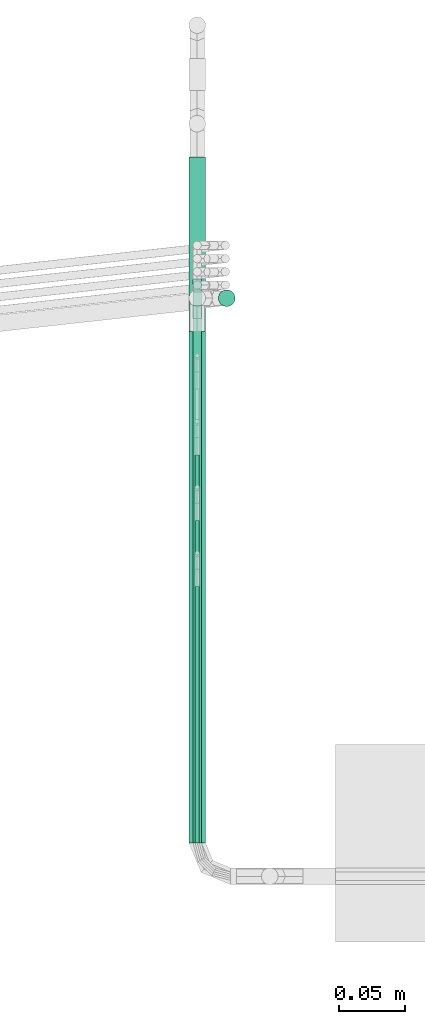
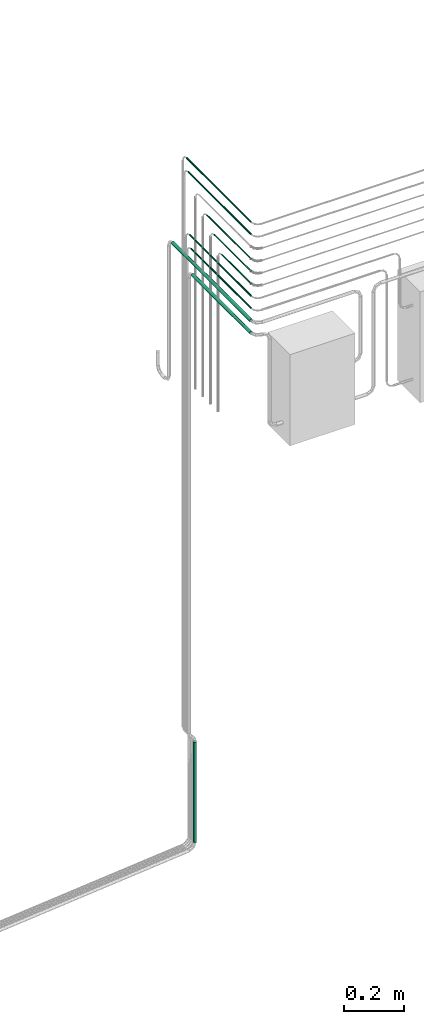
# One storey, part 20 of 45: 10 flow segments.
"""IFC2X3 building model written with IfcOpenShell, lengths in millimetres."""

from ifc_helpers import new_model, entity, si_unit, converted_unit, derived_unit, direction, frame, origin, origin_2d_with_axis, place, context, subcontext, project, spatial, circle, extrude, type_object, element, save


model = new_model("IFC2X3")

# Units and contexts
model_context = context("Model", 3, precision=0.01, world=origin(), true_north=direction((6.12303176911189e-17, 1.0)))
body_context = subcontext(model_context, "Body", "Model", "MODEL_VIEW")
ifc_project = project(units=[si_unit("LENGTHUNIT", "METRE", prefix="MILLI"), si_unit("AREAUNIT", "SQUARE_METRE"), si_unit("VOLUMEUNIT", "CUBIC_METRE"), converted_unit("PLANEANGLEUNIT", "DEGREE", entity("IfcRatioMeasure", 0.0174532925199433), si_unit("PLANEANGLEUNIT", "RADIAN"), dimensions=[0, 0, 0, 0, 0, 0, 0]), si_unit("MASSUNIT", "GRAM", prefix="KILO"), derived_unit("MASSDENSITYUNIT", [(si_unit("MASSUNIT", "GRAM", prefix="KILO"), 1), (si_unit("LENGTHUNIT", "METRE"), -3)]), derived_unit("MOMENTOFINERTIAUNIT", [(si_unit("LENGTHUNIT", "METRE"), 4)]), si_unit("TIMEUNIT", "SECOND"), si_unit("FREQUENCYUNIT", "HERTZ"), si_unit("THERMODYNAMICTEMPERATUREUNIT", "DEGREE_CELSIUS"), derived_unit("THERMALTRANSMITTANCEUNIT", [(si_unit("MASSUNIT", "GRAM", prefix="KILO"), 1), (si_unit("THERMODYNAMICTEMPERATUREUNIT", "KELVIN"), -1), (si_unit("TIMEUNIT", "SECOND"), -3)]), derived_unit("VOLUMETRICFLOWRATEUNIT", [(si_unit("LENGTHUNIT", "METRE"), 3), (si_unit("TIMEUNIT", "SECOND"), -1)]), derived_unit("MASSFLOWRATEUNIT", [(si_unit("MASSUNIT", "GRAM", prefix="KILO"), 1), (si_unit("TIMEUNIT", "SECOND"), -1)]), derived_unit("ROTATIONALFREQUENCYUNIT", [(si_unit("TIMEUNIT", "SECOND"), -1)]), si_unit("ELECTRICCURRENTUNIT", "AMPERE"), si_unit("ELECTRICVOLTAGEUNIT", "VOLT"), si_unit("POWERUNIT", "WATT"), si_unit("FORCEUNIT", "NEWTON", prefix="KILO"), si_unit("ILLUMINANCEUNIT", "LUX"), si_unit("LUMINOUSFLUXUNIT", "LUMEN"), si_unit("LUMINOUSINTENSITYUNIT", "CANDELA"), derived_unit("USERDEFINED", [(si_unit("MASSUNIT", "GRAM", prefix="KILO"), -1), (si_unit("LENGTHUNIT", "METRE"), -2), (si_unit("TIMEUNIT", "SECOND"), 3), (si_unit("LUMINOUSFLUXUNIT", "LUMEN"), 1)]), derived_unit("LINEARVELOCITYUNIT", [(si_unit("LENGTHUNIT", "METRE"), 1), (si_unit("TIMEUNIT", "SECOND"), -1)]), si_unit("PRESSUREUNIT", "PASCAL"), derived_unit("USERDEFINED", [(si_unit("LENGTHUNIT", "METRE"), -2), (si_unit("MASSUNIT", "GRAM", prefix="KILO"), 1), (si_unit("TIMEUNIT", "SECOND"), -2)]), derived_unit("LINEARFORCEUNIT", [(si_unit("MASSUNIT", "GRAM", prefix="KILO"), 1), (si_unit("LENGTHUNIT", "METRE"), 1), (si_unit("TIMEUNIT", "SECOND"), -2), (si_unit("LENGTHUNIT", "METRE"), -1)]), derived_unit("PLANARFORCEUNIT", [(si_unit("MASSUNIT", "GRAM", prefix="KILO"), 1), (si_unit("LENGTHUNIT", "METRE"), 1), (si_unit("TIMEUNIT", "SECOND"), -2), (si_unit("LENGTHUNIT", "METRE"), -2)])], contexts=[model_context])

# Site, building, storey
site_placement = place(None, frame((-24836.06, 8968.75, 0.0)))
site = spatial("IfcSite", under=ifc_project, at=site_placement, CompositionType="ELEMENT")
building_placement = place(site_placement, origin())
building = spatial("IfcBuilding", under=site, at=building_placement, CompositionType="ELEMENT")
storey_placement = place(building_placement, frame((0.0, 0.0, -4200.0)))
storey = spatial("IfcBuildingStorey", under=building, at=storey_placement, CompositionType="ELEMENT", Elevation=-4200.0)

# Flow segments
pipe_segment_type = type_object("IfcPipeSegmentType", PredefinedType="NOTDEFINED")
flow_segment_1_placement = place(storey_placement, frame((80740.98, -7563.35, 2045.23)))
element("IfcFlowSegment", 1, at=flow_segment_1_placement, inside=storey, type_object=pipe_segment_type, context=body_context, shape_type="SweptSolid", body=[
    extrude(circle(Radius=3.175, at=origin_2d_with_axis()), frame((4.77, 0.0, 4.77), z_axis=(0.0, 1.0, 0.0), x_axis=(-1.0, 0.0, 0.0)), (0.0, 0.0, 1.0), 398.712004781445),
])
flow_segment_2_placement = place(storey_placement, frame((80740.98, -7563.35, 2095.23)))
element("IfcFlowSegment", 2, at=flow_segment_2_placement, inside=storey, type_object=pipe_segment_type, context=body_context, shape_type="SweptSolid", body=[
    extrude(circle(Radius=3.175, at=origin_2d_with_axis()), frame((4.77, 0.0, 4.77), z_axis=(0.0, 1.0, 0.0), x_axis=(-1.0, 0.0, 0.0)), (0.0, 0.0, 1.0), 408.772453104694),
])
flow_segment_3_placement = place(storey_placement, frame((80740.98, -7563.35, 2345.23)))
element("IfcFlowSegment", 3, at=flow_segment_3_placement, inside=storey, type_object=pipe_segment_type, context=body_context, shape_type="SweptSolid", body=[
    extrude(circle(Radius=3.175, at=origin_2d_with_axis()), frame((4.77, 0.0, 4.77), z_axis=(0.0, 1.0, 0.0), x_axis=(-1.0, 0.0, 0.0)), (0.0, 0.0, 1.0), 418.83290142795),
])
flow_segment_4_placement = place(storey_placement, frame((80740.98, -7563.35, 2395.23)))
element("IfcFlowSegment", 4, at=flow_segment_4_placement, inside=storey, type_object=pipe_segment_type, context=body_context, shape_type="SweptSolid", body=[
    extrude(circle(Radius=3.175, at=origin_2d_with_axis()), frame((4.77, 0.0, 4.77), z_axis=(0.0, 1.0, 0.0), x_axis=(-1.0, 0.0, 0.0)), (0.0, 0.0, 1.0), 428.893349751199),
])
flow_segment_5_placement = place(storey_placement, frame((80760.28, -7157.13, -374.6)))
element("IfcFlowSegment", 5, at=flow_segment_5_placement, inside=storey, type_object=pipe_segment_type, context=body_context, shape_type="SweptSolid", body=[
    extrude(circle(Radius=6.35, at=origin_2d_with_axis()), frame((7.95, 7.95, 0.0), z_axis=(0.0, 0.0, 1.0), x_axis=(-1.0, 0.0, 0.0)), (0.0, 0.0, 1.0), 407.984401555602),
])
flow_segment_6_placement = place(storey_placement, frame((80737.81, -7563.35, 1942.05)))
element("IfcFlowSegment", 6, at=flow_segment_6_placement, inside=storey, type_object=pipe_segment_type, context=body_context, shape_type="SweptSolid", body=[
    extrude(circle(Radius=6.35, at=origin_2d_with_axis()), frame((7.95, 0.0, 7.95), z_axis=(0.0, 1.0, 0.0), x_axis=(-1.0, 0.0, 0.0)), (0.0, 0.0, 1.0), 388.772089900225),
])
flow_segment_7_placement = place(storey_placement, frame((80737.81, -7563.35, 1992.05)))
element("IfcFlowSegment", 7, at=flow_segment_7_placement, inside=storey, type_object=pipe_segment_type, context=body_context, shape_type="SweptSolid", body=[
    extrude(circle(Radius=6.35, at=origin_2d_with_axis()), frame((7.95, 0.0, 7.95), z_axis=(0.0, 1.0, 0.0), x_axis=(1.0, 0.0, 0.0)), (0.0, 0.0, 1.0), 521.393349751214),
])
flow_segment_8_placement = place(storey_placement, frame((80742.57, -7563.35, 2146.81)))
element("IfcFlowSegment", 8, at=flow_segment_8_placement, inside=storey, type_object=pipe_segment_type, context=body_context, shape_type="SweptSolid", body=[
    extrude(circle(Radius=1.59, at=origin_2d_with_axis()), frame((3.19, 0.0, 3.19), z_axis=(0.0, 1.0, 0.0), x_axis=(1.0, 0.0, 0.0)), (0.0, 0.0, 1.0), 195.064161667491),
])
flow_segment_9_placement = place(storey_placement, frame((80742.57, -7563.35, 2196.81)))
element("IfcFlowSegment", 9, at=flow_segment_9_placement, inside=storey, type_object=pipe_segment_type, context=body_context, shape_type="SweptSolid", body=[
    extrude(circle(Radius=1.59, at=origin_2d_with_axis()), frame((3.19, 0.0, 3.19), z_axis=(0.0, 1.0, 0.0), x_axis=(1.0, 0.0, 0.0)), (0.0, 0.0, 1.0), 245.064161667491),
])
flow_segment_10_placement = place(storey_placement, frame((80742.57, -7563.35, 2246.81)))
element("IfcFlowSegment", 10, at=flow_segment_10_placement, inside=storey, type_object=pipe_segment_type, context=body_context, shape_type="SweptSolid", body=[
    extrude(circle(Radius=1.59, at=origin_2d_with_axis()), frame((3.19, 0.0, 3.19), z_axis=(0.0, 1.0, 0.0), x_axis=(1.0, 0.0, 0.0)), (0.0, 0.0, 1.0), 295.064161667489),
])

save(model, "model.ifc")
